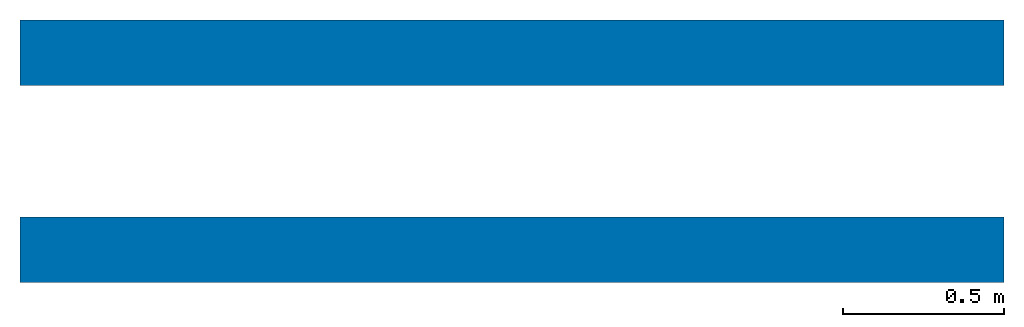
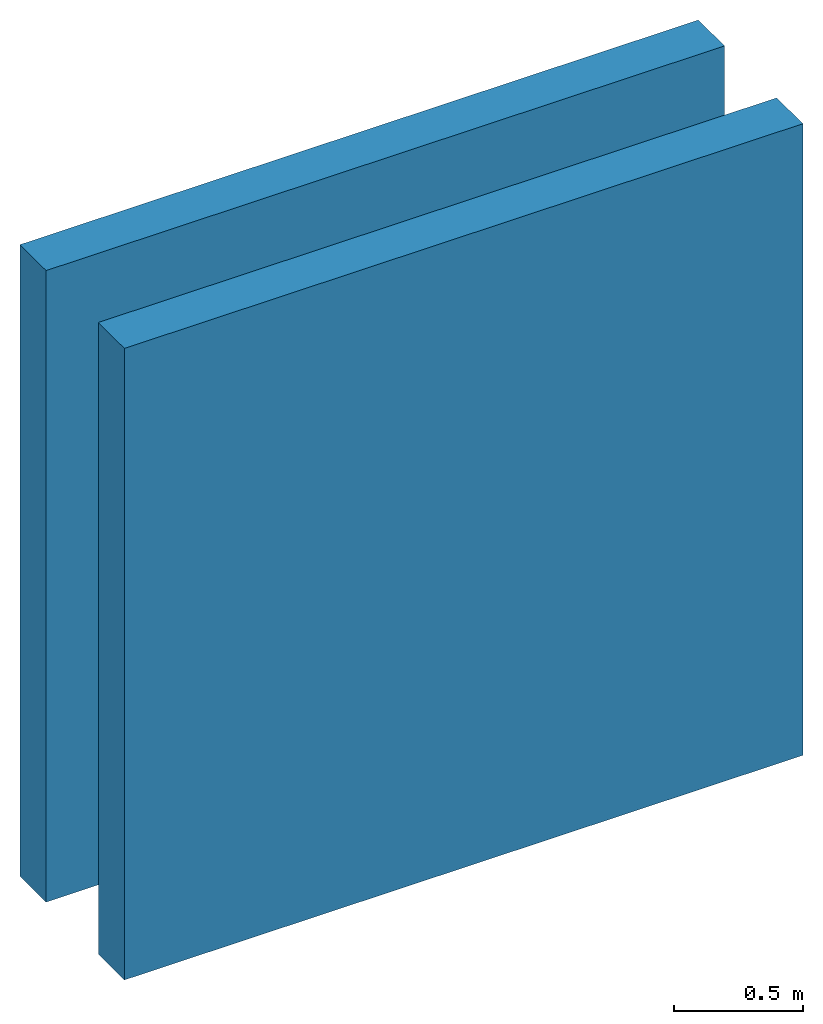
# One storey: 2 walls.
"""IFC4 building model written with IfcOpenShell, lengths in feet."""

from ifc_helpers import new_model, entity, si_unit, converted_unit, frame, frame_2d, origin_with_axes, place, context, subcontext, project, spatial, polyline, outline, extrude, material, layer, layer_set, layer_usage, type_object, element, save


model = new_model("IFC4")

# Units and contexts
model_context = context("Model", 3, precision=1e-05, world=origin_with_axes())
plan_context = context("Plan", 2, precision=1e-05, world=frame_2d((0.0, 0.0, 0.0), x_axis=(1.0, 0.0, 0.0)))
body_context = subcontext(model_context, "Body", "Model", "MODEL_VIEW")
ifc_project = project(units=[converted_unit("PLANEANGLEUNIT", "degree", entity("IfcReal", 0.0174532925199433), si_unit("PLANEANGLEUNIT", "RADIAN"), dimensions=[0, 0, 0, 0, 0, 0, 0]), converted_unit("AREAUNIT", "square foot", entity("IfcReal", 0.09290304), si_unit("AREAUNIT", "SQUARE_METRE"), dimensions=[2, 0, 0, 0, 0, 0, 0]), converted_unit("LENGTHUNIT", "foot", entity("IfcReal", 0.3048), si_unit("LENGTHUNIT", "METRE"), dimensions=[1, 0, 0, 0, 0, 0, 0]), converted_unit("VOLUMEUNIT", "cubic foot", entity("IfcReal", 0.0283168467116885), si_unit("VOLUMEUNIT", "CUBIC_METRE"), dimensions=[3, 0, 0, 0, 0, 0, 0])], contexts=[model_context, plan_context])

# Site, building, storey
site_placement = place(None, origin_with_axes())
site = spatial("IfcSite", under=ifc_project, at=site_placement)
building_placement = place(site_placement, origin_with_axes())
building = spatial("IfcBuilding", under=site, at=building_placement, Name="Building")
storey_placement = place(building_placement, origin_with_axes())
storey = spatial("IfcBuildingStorey", under=building, at=storey_placement, Name="Storey")

# Walls
ifc_material_1 = material(Name="1")
ifc_layer_1 = layer(ifc_material_1, 0.333333343267441)
ifc_material_2 = material(Name="2")
ifc_layer_2 = layer(ifc_material_2, 0.333333343267441)
ifc_layer_set = layer_set([ifc_layer_1, ifc_layer_2])
ifc_layer_usage_1 = layer_usage(ifc_layer_set, "AXIS2", "POSITIVE", 0.0)
wall_type = type_object("IfcWallType", Name="Empty", PredefinedType="ELEMENTEDWALL", material=ifc_layer_set)
wall_1_placement = place(storey_placement, origin_with_axes())
element("IfcWall", 1, at=wall_1_placement, inside=storey, type_object=wall_type, material=ifc_layer_usage_1, Name="Wall", context=body_context, shape_type="SweptSolid", body=[
    extrude(outline(polyline([(-0.333333353749097, -5.00000015957149), (0.333333353749097, -5.00000015957149), (0.333333353749097, 5.00000015957149), (-0.333333353749097, 5.00000015957149), (-0.333333353749097, -5.00000015957149)])), frame((5.00000015957149, 0.333333353749097, 0.0), z_axis=(0.0, 0.0, -1.0), x_axis=(0.0, -1.0, 0.0)), (0.0, 0.0, -1.0), 9.84251968503937),
])
ifc_layer_usage_2 = layer_usage(ifc_layer_set, "AXIS2", "POSITIVE", 0.0)
wall_2_placement = place(storey_placement, frame((0.0, 2.00000002471794, 0.0), z_axis=(0.0, 0.0, 1.0), x_axis=(1.0, 0.0, 0.0)))
element("IfcWall", 2, at=wall_2_placement, inside=storey, type_object=wall_type, material=ifc_layer_usage_2, Name="Wall", context=body_context, shape_type="SweptSolid", body=[
    extrude(outline(polyline([(-0.333333353749097, -5.00000015957149), (0.333333353749097, -5.00000015957149), (0.333333353749097, 5.00000015957149), (-0.333333353749097, 5.00000015957149), (-0.333333353749097, -5.00000015957149)])), frame((5.00000015957149, 0.333333353749097, 0.0), z_axis=(0.0, 0.0, -1.0), x_axis=(0.0, -1.0, 0.0)), (0.0, 0.0, -1.0), 9.84251968503937),
])

save(model, "model.ifc")
